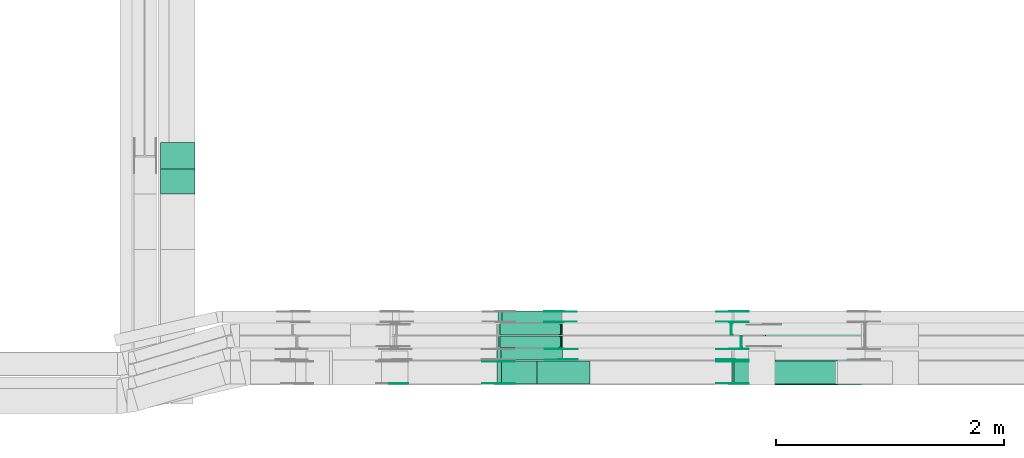
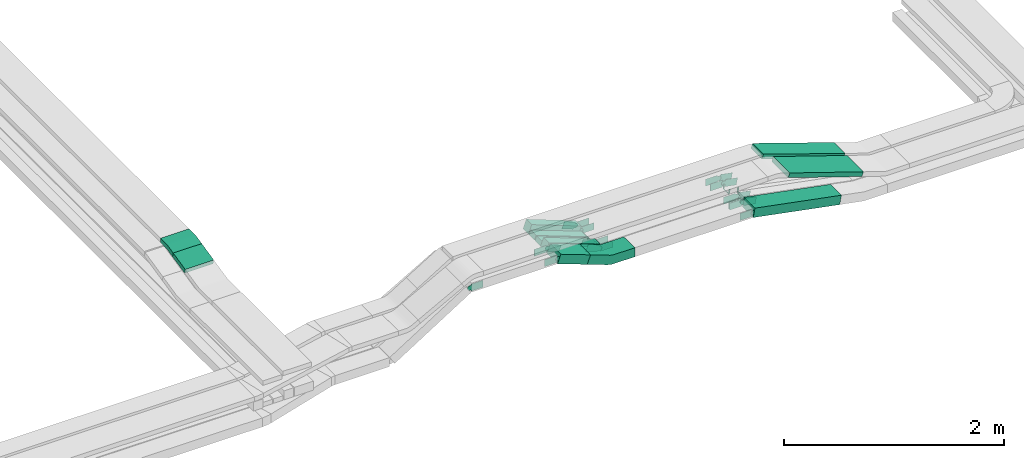
# One storey, part 24 of 28: 31 flow fittings, 9 flow segments.
"""IFC2X3 building model written with IfcOpenShell, lengths in millimetres."""

from ifc_helpers import new_model, entity, si_unit, converted_unit, derived_unit, direction, frame, frame_2d, origin, origin_2d_with_axis, place, context, subcontext, project, spatial, polyline, circle_curve, parameter, trimmed, segment, composite_curve, rectangle, outline, extrude, faceted_brep, source, transform, mapped, material, type_object, type_shapes, element, save


model = new_model("IFC2X3")

# Units and contexts
model_context = context("Model", 3, precision=0.01, world=origin(), true_north=direction((6.12303176911189e-17, 1.0)))
body_context = subcontext(model_context, "Body", "Model", "MODEL_VIEW")
ifc_project = project(units=[si_unit("LENGTHUNIT", "METRE", prefix="MILLI"), si_unit("AREAUNIT", "SQUARE_METRE"), si_unit("VOLUMEUNIT", "CUBIC_METRE"), converted_unit("PLANEANGLEUNIT", "DEGREE", entity("IfcRatioMeasure", 0.0174532925199433), si_unit("PLANEANGLEUNIT", "RADIAN"), dimensions=[0, 0, 0, 0, 0, 0, 0]), si_unit("MASSUNIT", "GRAM", prefix="KILO"), derived_unit("MASSDENSITYUNIT", [(si_unit("MASSUNIT", "GRAM", prefix="KILO"), 1), (si_unit("LENGTHUNIT", "METRE"), -3)]), derived_unit("MOMENTOFINERTIAUNIT", [(si_unit("LENGTHUNIT", "METRE"), 4)]), si_unit("TIMEUNIT", "SECOND"), si_unit("FREQUENCYUNIT", "HERTZ"), si_unit("THERMODYNAMICTEMPERATUREUNIT", "DEGREE_CELSIUS"), derived_unit("THERMALTRANSMITTANCEUNIT", [(si_unit("MASSUNIT", "GRAM", prefix="KILO"), 1), (si_unit("THERMODYNAMICTEMPERATUREUNIT", "KELVIN"), -1), (si_unit("TIMEUNIT", "SECOND"), -3)]), derived_unit("VOLUMETRICFLOWRATEUNIT", [(si_unit("LENGTHUNIT", "METRE"), 3), (si_unit("TIMEUNIT", "SECOND"), -1)]), derived_unit("MASSFLOWRATEUNIT", [(si_unit("MASSUNIT", "GRAM", prefix="KILO"), 1), (si_unit("TIMEUNIT", "SECOND"), -1)]), derived_unit("ROTATIONALFREQUENCYUNIT", [(si_unit("TIMEUNIT", "SECOND"), -1)]), si_unit("ELECTRICCURRENTUNIT", "AMPERE"), si_unit("ELECTRICVOLTAGEUNIT", "VOLT"), si_unit("POWERUNIT", "WATT"), si_unit("FORCEUNIT", "NEWTON", prefix="KILO"), si_unit("ILLUMINANCEUNIT", "LUX"), si_unit("LUMINOUSFLUXUNIT", "LUMEN"), si_unit("LUMINOUSINTENSITYUNIT", "CANDELA"), derived_unit("USERDEFINED", [(si_unit("MASSUNIT", "GRAM", prefix="KILO"), -1), (si_unit("LENGTHUNIT", "METRE"), -2), (si_unit("TIMEUNIT", "SECOND"), 3), (si_unit("LUMINOUSFLUXUNIT", "LUMEN"), 1)]), derived_unit("LINEARVELOCITYUNIT", [(si_unit("LENGTHUNIT", "METRE"), 1), (si_unit("TIMEUNIT", "SECOND"), -1)]), si_unit("PRESSUREUNIT", "PASCAL"), derived_unit("USERDEFINED", [(si_unit("LENGTHUNIT", "METRE"), -2), (si_unit("MASSUNIT", "GRAM", prefix="KILO"), 1), (si_unit("TIMEUNIT", "SECOND"), -2)]), derived_unit("LINEARFORCEUNIT", [(si_unit("MASSUNIT", "GRAM", prefix="KILO"), 1), (si_unit("LENGTHUNIT", "METRE"), 1), (si_unit("TIMEUNIT", "SECOND"), -2), (si_unit("LENGTHUNIT", "METRE"), -1)]), derived_unit("PLANARFORCEUNIT", [(si_unit("MASSUNIT", "GRAM", prefix="KILO"), 1), (si_unit("LENGTHUNIT", "METRE"), 1), (si_unit("TIMEUNIT", "SECOND"), -2), (si_unit("LENGTHUNIT", "METRE"), -2)])], contexts=[model_context])

# Site, building, storey
site_placement = place(None, origin())
site = spatial("IfcSite", under=ifc_project, at=site_placement, CompositionType="ELEMENT")
building_placement = place(site_placement, origin())
building = spatial("IfcBuilding", under=site, at=building_placement, CompositionType="ELEMENT")
storey_placement = place(building_placement, frame((0.0, 0.0, 15900.0)))
storey = spatial("IfcBuildingStorey", under=building, at=storey_placement, CompositionType="ELEMENT", Elevation=15900.0)

# Flow segments
cable_carrier_segment_type = type_object("IfcCableCarrierSegmentType", PredefinedType="CABLETRAYSEGMENT")
flow_segment_1_placement = place(storey_placement, frame((60480.82, 10142.24, 2935.93)))
element("IfcFlowSegment", 1, at=flow_segment_1_placement, inside=storey, type_object=cable_carrier_segment_type, context=body_context, shape_type="SweptSolid", body=[
    extrude(rectangle(XDim=49.999999999999, YDim=224.379471632193, at=frame_2d((0.0, 0.0), x_axis=(0.0, 1.0))), frame((0.0, 114.94, 49.17), z_axis=(1.0, 0.0, 0.0), x_axis=(0.0, 0.975283876332618, 0.220955562422907)), (0.0, 0.0, 1.0), 300.000000000001),
])
flow_segment_2_placement = place(storey_placement, frame((63434.61, 8474.97, 2908.57)))
element("IfcFlowSegment", 2, at=flow_segment_2_placement, inside=storey, type_object=cable_carrier_segment_type, context=body_context, shape_type="SweptSolid", body=[
    extrude(rectangle(XDim=100.000000000008, YDim=200.0, at=origin_2d_with_axis()), frame((17.45, 100.0, 163.12), z_axis=(0.93710827946644, 0.0, -0.349038783741073), x_axis=(0.349038783741073, 0.0, 0.93710827946644)), (0.0, 0.0, 1.0), 333.090848665879),
])
flow_segment_3_placement = place(storey_placement, frame((63431.17, 8684.97, 2825.3)))
element("IfcFlowSegment", 3, at=flow_segment_3_placement, inside=storey, type_object=cable_carrier_segment_type, context=body_context, shape_type="SweptSolid", body=[
    extrude(rectangle(XDim=99.9999999999998, YDim=99.9999999999989, at=origin_2d_with_axis()), frame((17.36, 50.0, 246.43), z_axis=(0.937801944103858, 0.0, -0.347170726927005), x_axis=(0.347170726927005, 0.0, 0.937801944103858)), (0.0, 0.0, 1.0), 574.76976896054),
])
flow_segment_4_placement = place(storey_placement, frame((63439.05, 8794.97, 2823.23)))
element("IfcFlowSegment", 4, at=flow_segment_4_placement, inside=storey, type_object=cable_carrier_segment_type, context=body_context, shape_type="SweptSolid", body=[
    extrude(rectangle(XDim=49.9999999999989, YDim=99.9999999999989, at=origin_2d_with_axis()), frame((8.75, 50.0, 224.05), z_axis=(0.936732432746274, 0.0, -0.350046210436919), x_axis=(0.350046210436919, 0.0, 0.936732432746274)), (0.0, 0.0, 1.0), 573.147793888569),
])
flow_segment_5_placement = place(storey_placement, frame((63439.91, 8904.97, 2823.24)))
element("IfcFlowSegment", 5, at=flow_segment_5_placement, inside=storey, type_object=cable_carrier_segment_type, context=body_context, shape_type="SweptSolid", body=[
    extrude(rectangle(XDim=50.0000000000006, YDim=100.000000000001, at=origin_2d_with_axis()), frame((8.76, 50.0, 224.03), z_axis=(0.936565915076029, 0.0, -0.350491493074798), x_axis=(0.350491493074798, 0.0, 0.936565915076029)), (0.0, 0.0, 1.0), 572.372127334818),
])
flow_segment_6_placement = place(storey_placement, frame((63439.46, 9014.97, 2825.64)))
element("IfcFlowSegment", 6, at=flow_segment_6_placement, inside=storey, type_object=cable_carrier_segment_type, context=body_context, shape_type="SweptSolid", body=[
    extrude(rectangle(XDim=99.9999999999993, YDim=100.000000000001, at=origin_2d_with_axis()), frame((17.79, 50.0, 245.91), z_axis=(0.934589453965198, 0.0, -0.355728200367967), x_axis=(0.355728200367967, 0.0, 0.934589453965198)), (0.0, 0.0, 1.0), 559.919552112584),
])
flow_segment_7_placement = place(storey_placement, frame((65492.26, 8474.97, 2643.47)))
element("IfcFlowSegment", 7, at=flow_segment_7_placement, inside=storey, type_object=cable_carrier_segment_type, context=body_context, shape_type="SweptSolid", body=[
    extrude(rectangle(XDim=100.000000000002, YDim=200.0, at=origin_2d_with_axis()), frame((9.43, 100.0, 223.85), z_axis=(0.982035536310349, 0.0, -0.188696066264366), x_axis=(0.188696066264366, 0.0, 0.982035536310349)), (0.0, 0.0, 1.0), 926.06458101267),
])
flow_segment_8_placement = place(storey_placement, frame((65854.05, 8465.15, 2881.95)))
element("IfcFlowSegment", 8, at=flow_segment_8_placement, inside=storey, type_object=cable_carrier_segment_type, context=body_context, shape_type="SweptSolid", body=[
    extrude(rectangle(XDim=50.0000000000008, YDim=300.000000000001, at=origin_2d_with_axis()), frame((7.9, 150.0, 282.03), z_axis=(0.948754815223127, 0.0, -0.316013133573479), x_axis=(0.316013133573479, 0.0, 0.948754815223127)), (0.0, 0.0, 1.0), 817.406380375089),
])
flow_segment_9_placement = place(storey_placement, frame((65771.27, 8800.15, 2883.35)))
element("IfcFlowSegment", 9, at=flow_segment_9_placement, inside=storey, type_object=cable_carrier_segment_type, context=body_context, shape_type="SweptSolid", body=[
    extrude(rectangle(XDim=50.000000000002, YDim=200.0, at=origin_2d_with_axis()), frame((8.03, 100.0, 314.8), z_axis=(0.947026352753396, 0.0, -0.321155861211656), x_axis=(0.321155861211656, 0.0, 0.947026352753396)), (0.0, 0.0, 1.0), 906.476874126866),
])

# Flow fittings
ifc_material_1 = material()
cable_carrier_fitting_type_1 = type_object("IfcCableCarrierFittingType", PredefinedType="NOTDEFINED", material=ifc_material_1)
shared_shape_1 = source(origin(), body_context, "Body", "Brep", [
    faceted_brep([(-9.04, 25.0, 50.0), (-9.04, 25.0, -50.0), (-9.04, -25.0, -50.0), (-9.04, -25.0, -47.46), (-9.04, 22.46, -47.46), (-9.04, 22.46, 47.46), (-9.04, -25.0, 47.46), (-9.04, -25.0, 50.0), (-0.29, 26.58, 50.0), (17.22, -20.25, 50.0), (17.22, -20.25, 47.46), (0.6, 24.2, 47.46), (0.6, 24.2, -47.46), (17.22, -20.25, -47.46), (17.22, -20.25, -50.0), (-0.29, 26.58, -50.0), (-4.52, 25.0, 50.0), (-4.52, 25.0, -50.0), (4.52, -25.0, -50.0), (4.52, -25.0, -47.46), (-4.06, 22.46, -47.46), (-4.06, 22.46, 47.46), (4.52, -25.0, 47.46), (4.52, -25.0, 50.0)], [[[0, 1, 2, 3, 4, 5, 6, 7]], [[8, 9, 10, 11, 12, 13, 14, 15]], [[1, 0, 16, 17]], [[2, 1, 17, 15, 14, 18]], [[3, 2, 18, 19]], [[4, 3, 19, 13, 12, 20]], [[5, 4, 20, 21]], [[6, 5, 21, 11, 10, 22]], [[7, 6, 22, 23]], [[0, 7, 23, 9, 8, 16]], [[17, 16, 8, 15]], [[19, 18, 14, 13]], [[21, 20, 12, 11]], [[23, 22, 10, 9]]]),
])
type_shapes(cable_carrier_fitting_type_1, [shared_shape_1])
flow_fitting_1_placement = place(storey_placement, frame((63993.15, 8844.97, 2843.48), z_axis=(0.0, -1.0, 0.0), x_axis=(0.936732432746256, 0.0, -0.350046210436966)))
element("IfcFlowFitting", 10, at=flow_fitting_1_placement, inside=storey, type_object=cable_carrier_fitting_type_1, material=ifc_material_1, context=body_context, shape_type="MappedRepresentation", body=[
    mapped(shared_shape_1, transform((0.0, 0.0, 0.0), scale=1.0)),
])
cable_carrier_fitting_type_2 = type_object("IfcCableCarrierFittingType", PredefinedType="NOTDEFINED", material=ifc_material_1)
shared_shape_2 = source(origin(), body_context, "Body", "Brep", [
    faceted_brep([(-9.05, 25.0, 50.0), (-9.05, 25.0, -50.0), (-9.05, -25.0, -50.0), (-9.05, -25.0, -47.46), (-9.05, 22.46, -47.46), (-9.05, 22.46, 47.46), (-9.05, -25.0, 47.46), (-9.05, -25.0, 50.0), (-0.29, 26.59, 50.0), (17.24, -20.24, 50.0), (17.24, -20.24, 47.46), (0.6, 24.21, 47.46), (0.6, 24.21, -47.46), (17.24, -20.24, -47.46), (17.24, -20.24, -50.0), (-0.29, 26.59, -50.0), (-4.52, 25.0, 50.0), (-4.52, 25.0, -50.0), (4.52, -25.0, -50.0), (4.52, -25.0, -47.46), (-4.06, 22.46, -47.46), (-4.06, 22.46, 47.46), (4.52, -25.0, 47.46), (4.52, -25.0, 50.0)], [[[0, 1, 2, 3, 4, 5, 6, 7]], [[8, 9, 10, 11, 12, 13, 14, 15]], [[1, 0, 16, 17]], [[2, 1, 17, 15, 14, 18]], [[3, 2, 18, 19]], [[4, 3, 19, 13, 12, 20]], [[5, 4, 20, 21]], [[6, 5, 21, 11, 10, 22]], [[7, 6, 22, 23]], [[0, 7, 23, 9, 8, 16]], [[17, 16, 8, 15]], [[19, 18, 14, 13]], [[21, 20, 12, 11]], [[23, 22, 10, 9]]]),
])
type_shapes(cable_carrier_fitting_type_2, [shared_shape_2])
flow_fitting_2_placement = place(storey_placement, frame((63993.21, 8954.97, 2843.48), z_axis=(0.0, 1.0, 0.0), x_axis=(-1.0, 0.0, 0.0)))
element("IfcFlowFitting", 11, at=flow_fitting_2_placement, inside=storey, type_object=cable_carrier_fitting_type_2, material=ifc_material_1, context=body_context, shape_type="MappedRepresentation", body=[
    mapped(shared_shape_2, transform((0.0, 0.0, 0.0), scale=1.0)),
])
cable_carrier_fitting_type_3 = type_object("IfcCableCarrierFittingType", PredefinedType="NOTDEFINED", material=ifc_material_1)
shared_shape_3 = source(origin(), body_context, "Body", "Brep", [
    faceted_brep([(-5.06, 25.0, 50.0), (-5.06, 25.0, -50.0), (-5.06, -25.0, -50.0), (-5.06, -25.0, -47.46), (-5.06, 22.46, -47.46), (-5.06, 22.46, 47.46), (-5.06, -25.0, 47.46), (-5.06, -25.0, 50.0), (-0.05, 25.51, 50.0), (9.97, -23.48, 50.0), (9.97, -23.48, 47.46), (0.46, 23.02, 47.46), (0.46, 23.02, -47.46), (9.97, -23.48, -47.46), (9.97, -23.48, -50.0), (-0.05, 25.51, -50.0), (-2.53, 25.0, 50.0), (-2.53, 25.0, -50.0), (2.53, -25.0, -50.0), (2.53, -25.0, -47.46), (-2.27, 22.46, -47.46), (-2.27, 22.46, 47.46), (2.53, -25.0, 47.46), (2.53, -25.0, 50.0)], [[[0, 1, 2, 3, 4, 5, 6, 7]], [[8, 9, 10, 11, 12, 13, 14, 15]], [[1, 0, 16, 17]], [[2, 1, 17, 15, 14, 18]], [[3, 2, 18, 19]], [[4, 3, 19, 13, 12, 20]], [[5, 4, 20, 21]], [[6, 5, 21, 11, 10, 22]], [[7, 6, 22, 23]], [[0, 7, 23, 9, 8, 16]], [[17, 16, 8, 15]], [[19, 18, 14, 13]], [[21, 20, 12, 11]], [[23, 22, 10, 9]]]),
])
type_shapes(cable_carrier_fitting_type_3, [shared_shape_3])
flow_fitting_3_placement = place(storey_placement, frame((65573.15, 8844.97, 2843.48), z_axis=(0.0, 1.0, 0.0), x_axis=(1.0, 0.0, 0.0)))
element("IfcFlowFitting", 12, at=flow_fitting_3_placement, inside=storey, type_object=cable_carrier_fitting_type_3, material=ifc_material_1, context=body_context, shape_type="MappedRepresentation", body=[
    mapped(shared_shape_3, transform((0.0, 0.0, 0.0), scale=1.0)),
])
cable_carrier_fitting_type_4 = type_object("IfcCableCarrierFittingType", PredefinedType="NOTDEFINED", material=ifc_material_1)
shared_shape_4 = source(origin(), body_context, "Body", "Brep", [
    faceted_brep([(-4.7, 25.0, 50.0), (-4.7, 25.0, -50.0), (-4.7, -25.0, -50.0), (-4.7, -25.0, -47.46), (-4.7, 22.46, -47.46), (-4.7, 22.46, 47.46), (-4.7, -25.0, 47.46), (-4.7, -25.0, 50.0), (-0.04, 25.44, 50.0), (9.28, -23.69, 50.0), (9.28, -23.69, 47.46), (0.43, 22.94, 47.46), (0.43, 22.94, -47.46), (9.28, -23.69, -47.46), (9.28, -23.69, -50.0), (-0.04, 25.44, -50.0), (-2.35, 25.0, 50.0), (-2.35, 25.0, -50.0), (2.35, -25.0, -50.0), (2.35, -25.0, -47.46), (-2.11, 22.46, -47.46), (-2.11, 22.46, 47.46), (2.35, -25.0, 47.46), (2.35, -25.0, 50.0)], [[[0, 1, 2, 3, 4, 5, 6, 7]], [[8, 9, 10, 11, 12, 13, 14, 15]], [[1, 0, 16, 17]], [[2, 1, 17, 15, 14, 18]], [[3, 2, 18, 19]], [[4, 3, 19, 13, 12, 20]], [[5, 4, 20, 21]], [[6, 5, 21, 11, 10, 22]], [[7, 6, 22, 23]], [[0, 7, 23, 9, 8, 16]], [[17, 16, 8, 15]], [[19, 18, 14, 13]], [[21, 20, 12, 11]], [[23, 22, 10, 9]]]),
])
type_shapes(cable_carrier_fitting_type_4, [shared_shape_4])
flow_fitting_4_placement = place(storey_placement, frame((65488.23, 8954.97, 2843.48), z_axis=(0.0, 1.0, 0.0), x_axis=(1.0, 0.0, 0.0)))
element("IfcFlowFitting", 13, at=flow_fitting_4_placement, inside=storey, type_object=cable_carrier_fitting_type_4, material=ifc_material_1, context=body_context, shape_type="MappedRepresentation", body=[
    mapped(shared_shape_4, transform((0.0, 0.0, 0.0), scale=1.0)),
])
ifc_material_2 = material(Name="G")
cable_carrier_fitting_type_5 = type_object("IfcCableCarrierFittingType", PredefinedType="NOTDEFINED", material=ifc_material_2)
shared_shape_5 = source(origin(), body_context, "Body", "SweptSolid", [
    extrude(outline(composite_curve([segment(trimmed(circle_curve(frame_2d((-41.47, 0.0), x_axis=(1.0, 0.0)), 25.0), [parameter(90.0000000000007)], [parameter(270.0)], True, "PARAMETER"), True, "CONTINUOUS"), segment(polyline([(-41.47, -25.0), (-29.97, -25.0)]), True, "CONTINUOUS"), segment(polyline([(-29.97, -25.0), (-28.1, -38.5)]), True, "CONTINUOUS"), segment(polyline([(-28.1, -38.5), (99.53, -38.5)]), True, "CONTINUOUS"), segment(polyline([(99.53, -38.5), (99.53, 38.5)]), True, "CONTINUOUS"), segment(polyline([(99.53, 38.5), (-28.1, 38.5)]), True, "CONTINUOUS"), segment(polyline([(-28.1, 38.5), (-29.97, 25.0)]), True, "CONTINUOUS"), segment(polyline([(-29.97, 25.0), (-41.47, 25.0)]), True, "CONTINUOUS")], self_intersect=False)), frame((41.47, 0.0, 0.0), z_axis=(0.0, 0.0, -1.0), x_axis=(1.0, 0.0, 0.0)), (0.0, 0.0, -1.0), 2.0),
])
type_shapes(cable_carrier_fitting_type_5, [shared_shape_5])
flow_fitting_5_placement = place(storey_placement, frame((65495.66, 8780.43, 2868.48), z_axis=(0.0, 1.0, 0.0), x_axis=(0.982035536310358, 0.0, -0.188696066264316)))
element("IfcFlowFitting", 14, at=flow_fitting_5_placement, inside=storey, type_object=cable_carrier_fitting_type_5, material=ifc_material_2, context=body_context, shape_type="MappedRepresentation", body=[
    mapped(shared_shape_5, transform((0.0, 0.0, 0.0), scale=1.0)),
])
cable_carrier_fitting_type_6 = type_object("IfcCableCarrierFittingType", PredefinedType="NOTDEFINED", material=ifc_material_2)
type_shapes(cable_carrier_fitting_type_6, [shared_shape_5])
flow_fitting_6_placement = place(storey_placement, frame((65495.66, 8691.51, 2868.48), z_axis=(0.0, -1.0, 0.0), x_axis=(-1.0, 0.0, 0.0)))
element("IfcFlowFitting", 15, at=flow_fitting_6_placement, inside=storey, type_object=cable_carrier_fitting_type_6, material=ifc_material_2, context=body_context, shape_type="MappedRepresentation", body=[
    mapped(shared_shape_5, transform((0.0, 0.0, 0.0), scale=1.0)),
])
flow_fitting_7_placement = place(storey_placement, frame((65495.66, 9110.43, 2868.48), z_axis=(0.0, 1.0, 0.0), x_axis=(0.982035536310358, 0.0, -0.188696066264316)))
element("IfcFlowFitting", 16, at=flow_fitting_7_placement, inside=storey, type_object=cable_carrier_fitting_type_5, material=ifc_material_2, context=body_context, shape_type="MappedRepresentation", body=[
    mapped(shared_shape_5, transform((0.0, 0.0, 0.0), scale=1.0)),
])
flow_fitting_8_placement = place(storey_placement, frame((65495.66, 9021.51, 2868.48), z_axis=(0.0, -1.0, 0.0), x_axis=(-1.0, 0.0, 0.0)))
element("IfcFlowFitting", 17, at=flow_fitting_8_placement, inside=storey, type_object=cable_carrier_fitting_type_6, material=ifc_material_2, context=body_context, shape_type="MappedRepresentation", body=[
    mapped(shared_shape_5, transform((0.0, 0.0, 0.0), scale=1.0)),
])
flow_fitting_9_placement = place(storey_placement, frame((63997.56, 8780.43, 2868.48), z_axis=(0.0, 1.0, 0.0), x_axis=(-0.937801944103825, 0.0, 0.347170726927093)))
element("IfcFlowFitting", 18, at=flow_fitting_9_placement, inside=storey, type_object=cable_carrier_fitting_type_5, material=ifc_material_2, context=body_context, shape_type="MappedRepresentation", body=[
    mapped(shared_shape_5, transform((0.0, 0.0, 0.0), scale=1.0)),
])
flow_fitting_10_placement = place(storey_placement, frame((63997.56, 8691.51, 2868.48), z_axis=(0.0, -1.0, 0.0), x_axis=(1.0, 0.0, 0.0)))
element("IfcFlowFitting", 19, at=flow_fitting_10_placement, inside=storey, type_object=cable_carrier_fitting_type_6, material=ifc_material_2, context=body_context, shape_type="MappedRepresentation", body=[
    mapped(shared_shape_5, transform((0.0, 0.0, 0.0), scale=1.0)),
])
flow_fitting_11_placement = place(storey_placement, frame((63990.75, 9110.43, 2868.48), z_axis=(0.0, 1.0, 0.0), x_axis=(-0.934589453965168, 0.0, 0.355728200368047)))
element("IfcFlowFitting", 20, at=flow_fitting_11_placement, inside=storey, type_object=cable_carrier_fitting_type_5, material=ifc_material_2, context=body_context, shape_type="MappedRepresentation", body=[
    mapped(shared_shape_5, transform((0.0, 0.0, 0.0), scale=1.0)),
])
flow_fitting_12_placement = place(storey_placement, frame((63990.75, 9021.51, 2868.48), z_axis=(0.0, -1.0, 0.0), x_axis=(1.0, 0.0, 0.0)))
element("IfcFlowFitting", 21, at=flow_fitting_12_placement, inside=storey, type_object=cable_carrier_fitting_type_6, material=ifc_material_2, context=body_context, shape_type="MappedRepresentation", body=[
    mapped(shared_shape_5, transform((0.0, 0.0, 0.0), scale=1.0)),
])
flow_fitting_13_placement = place(storey_placement, frame((63442.0, 8670.43, 3075.44), z_axis=(0.0, 1.0, 0.0), x_axis=(0.937108279466473, 0.0, -0.349038783740986)))
element("IfcFlowFitting", 22, at=flow_fitting_13_placement, inside=storey, type_object=cable_carrier_fitting_type_5, material=ifc_material_2, context=body_context, shape_type="MappedRepresentation", body=[
    mapped(shared_shape_5, transform((0.0, 0.0, 0.0), scale=1.0)),
])
flow_fitting_14_placement = place(storey_placement, frame((63442.0, 8481.51, 3075.44), z_axis=(0.0, -1.0, 0.0), x_axis=(-1.0, 0.0, 0.0)))
element("IfcFlowFitting", 23, at=flow_fitting_14_placement, inside=storey, type_object=cable_carrier_fitting_type_6, material=ifc_material_2, context=body_context, shape_type="MappedRepresentation", body=[
    mapped(shared_shape_5, transform((0.0, 0.0, 0.0), scale=1.0)),
])
flow_fitting_15_placement = place(storey_placement, frame((65495.66, 8670.43, 2868.48), z_axis=(0.0, 1.0, 0.0), x_axis=(0.982035536310354, 0.0, -0.18869606626434)))
element("IfcFlowFitting", 24, at=flow_fitting_15_placement, inside=storey, type_object=cable_carrier_fitting_type_5, material=ifc_material_2, context=body_context, shape_type="MappedRepresentation", body=[
    mapped(shared_shape_5, transform((0.0, 0.0, 0.0), scale=1.0)),
])
flow_fitting_16_placement = place(storey_placement, frame((65495.66, 8481.51, 2868.48), z_axis=(0.0, -1.0, 0.0), x_axis=(-1.0, 0.0, 0.0)))
element("IfcFlowFitting", 25, at=flow_fitting_16_placement, inside=storey, type_object=cable_carrier_fitting_type_6, material=ifc_material_2, context=body_context, shape_type="MappedRepresentation", body=[
    mapped(shared_shape_5, transform((0.0, 0.0, 0.0), scale=1.0)),
])
cable_carrier_fitting_type_7 = type_object("IfcCableCarrierFittingType", PredefinedType="NOTDEFINED", material=ifc_material_2)
shared_shape_6 = source(origin(), body_context, "Body", "SweptSolid", [
    extrude(outline(composite_curve([segment(trimmed(circle_curve(frame_2d((-41.47, 0.0), x_axis=(1.0, 0.0)), 25.0), [parameter(90.0000000000007)], [parameter(270.0)], True, "PARAMETER"), True, "CONTINUOUS"), segment(polyline([(-41.47, -25.0), (-29.97, -25.0)]), True, "CONTINUOUS"), segment(polyline([(-29.97, -25.0), (-28.1, -38.5)]), True, "CONTINUOUS"), segment(polyline([(-28.1, -38.5), (99.53, -38.5)]), True, "CONTINUOUS"), segment(polyline([(99.53, -38.5), (99.53, 38.5)]), True, "CONTINUOUS"), segment(polyline([(99.53, 38.5), (-28.1, 38.5)]), True, "CONTINUOUS"), segment(polyline([(-28.1, 38.5), (-29.97, 25.0)]), True, "CONTINUOUS"), segment(polyline([(-29.97, 25.0), (-41.47, 25.0)]), True, "CONTINUOUS")], self_intersect=False)), frame((41.47, 0.0, 0.0)), (0.0, 0.0, 1.0), 2.0),
])
type_shapes(cable_carrier_fitting_type_7, [shared_shape_6])
flow_fitting_17_placement = place(storey_placement, frame((65495.66, 8689.51, 2868.48), z_axis=(0.0, -1.0, 0.0), x_axis=(0.982035536310358, 0.0, -0.188696066264316)))
element("IfcFlowFitting", 26, at=flow_fitting_17_placement, inside=storey, type_object=cable_carrier_fitting_type_7, material=ifc_material_2, context=body_context, shape_type="MappedRepresentation", body=[
    mapped(shared_shape_6, transform((0.0, 0.0, 0.0), scale=1.0)),
])
cable_carrier_fitting_type_8 = type_object("IfcCableCarrierFittingType", PredefinedType="NOTDEFINED", material=ifc_material_2)
type_shapes(cable_carrier_fitting_type_8, [shared_shape_6])
flow_fitting_18_placement = place(storey_placement, frame((65495.66, 8778.43, 2868.48), z_axis=(0.0, 1.0, 0.0), x_axis=(-1.0, 0.0, 0.0)))
element("IfcFlowFitting", 27, at=flow_fitting_18_placement, inside=storey, type_object=cable_carrier_fitting_type_8, material=ifc_material_2, context=body_context, shape_type="MappedRepresentation", body=[
    mapped(shared_shape_6, transform((0.0, 0.0, 0.0), scale=1.0)),
])
flow_fitting_19_placement = place(storey_placement, frame((65495.66, 9019.51, 2868.48), z_axis=(0.0, -1.0, 0.0), x_axis=(0.982035536310358, 0.0, -0.188696066264316)))
element("IfcFlowFitting", 28, at=flow_fitting_19_placement, inside=storey, type_object=cable_carrier_fitting_type_7, material=ifc_material_2, context=body_context, shape_type="MappedRepresentation", body=[
    mapped(shared_shape_6, transform((0.0, 0.0, 0.0), scale=1.0)),
])
flow_fitting_20_placement = place(storey_placement, frame((65495.66, 9108.43, 2868.48), z_axis=(0.0, 1.0, 0.0), x_axis=(-1.0, 0.0, 0.0)))
element("IfcFlowFitting", 29, at=flow_fitting_20_placement, inside=storey, type_object=cable_carrier_fitting_type_8, material=ifc_material_2, context=body_context, shape_type="MappedRepresentation", body=[
    mapped(shared_shape_6, transform((0.0, 0.0, 0.0), scale=1.0)),
])
flow_fitting_21_placement = place(storey_placement, frame((63997.56, 8689.51, 2868.48), z_axis=(0.0, -1.0, 0.0), x_axis=(-0.937801944103825, 0.0, 0.347170726927093)))
element("IfcFlowFitting", 30, at=flow_fitting_21_placement, inside=storey, type_object=cable_carrier_fitting_type_7, material=ifc_material_2, context=body_context, shape_type="MappedRepresentation", body=[
    mapped(shared_shape_6, transform((0.0, 0.0, 0.0), scale=1.0)),
])
flow_fitting_22_placement = place(storey_placement, frame((63997.56, 8778.43, 2868.48), z_axis=(0.0, 1.0, 0.0), x_axis=(1.0, 0.0, 0.0)))
element("IfcFlowFitting", 31, at=flow_fitting_22_placement, inside=storey, type_object=cable_carrier_fitting_type_8, material=ifc_material_2, context=body_context, shape_type="MappedRepresentation", body=[
    mapped(shared_shape_6, transform((0.0, 0.0, 0.0), scale=1.0)),
])
flow_fitting_23_placement = place(storey_placement, frame((63990.75, 9019.51, 2868.48), z_axis=(0.0, -1.0, 0.0), x_axis=(-0.934589453965168, 0.0, 0.355728200368047)))
element("IfcFlowFitting", 32, at=flow_fitting_23_placement, inside=storey, type_object=cable_carrier_fitting_type_7, material=ifc_material_2, context=body_context, shape_type="MappedRepresentation", body=[
    mapped(shared_shape_6, transform((0.0, 0.0, 0.0), scale=1.0)),
])
flow_fitting_24_placement = place(storey_placement, frame((63990.75, 9108.43, 2868.48), z_axis=(0.0, 1.0, 0.0), x_axis=(1.0, 0.0, 0.0)))
element("IfcFlowFitting", 33, at=flow_fitting_24_placement, inside=storey, type_object=cable_carrier_fitting_type_8, material=ifc_material_2, context=body_context, shape_type="MappedRepresentation", body=[
    mapped(shared_shape_6, transform((0.0, 0.0, 0.0), scale=1.0)),
])
for number, where, z_axis, x_axis in (
    (34, (62513.11, 8479.51, 3075.44), (0.0, -1.0, 0.0), (1.0, 0.0, 0.0)),
    (35, (63442.0, 8479.51, 3075.44), (0.0, -1.0, 0.0), (0.937108279466473, 0.0, -0.349038783740986)),
):
    element("IfcFlowFitting", number, at=place(storey_placement, frame(where, z_axis=z_axis, x_axis=x_axis)), inside=storey, type_object=cable_carrier_fitting_type_7, material=ifc_material_2, context=body_context, shape_type="MappedRepresentation", body=[
        mapped(shared_shape_6, transform((0.0, 0.0, 0.0), scale=1.0)),
    ])
flow_fitting_25_placement = place(storey_placement, frame((63442.0, 8668.43, 3075.44), z_axis=(0.0, 1.0, 0.0), x_axis=(-1.0, 0.0, 0.0)))
element("IfcFlowFitting", 36, at=flow_fitting_25_placement, inside=storey, type_object=cable_carrier_fitting_type_8, material=ifc_material_2, context=body_context, shape_type="MappedRepresentation", body=[
    mapped(shared_shape_6, transform((0.0, 0.0, 0.0), scale=1.0)),
])
flow_fitting_26_placement = place(storey_placement, frame((65495.66, 8479.51, 2868.48), z_axis=(0.0, -1.0, 0.0), x_axis=(0.982035536310354, 0.0, -0.18869606626434)))
element("IfcFlowFitting", 37, at=flow_fitting_26_placement, inside=storey, type_object=cable_carrier_fitting_type_7, material=ifc_material_2, context=body_context, shape_type="MappedRepresentation", body=[
    mapped(shared_shape_6, transform((0.0, 0.0, 0.0), scale=1.0)),
])
flow_fitting_27_placement = place(storey_placement, frame((65495.66, 8668.43, 2868.48), z_axis=(0.0, 1.0, 0.0), x_axis=(-1.0, 0.0, 0.0)))
element("IfcFlowFitting", 38, at=flow_fitting_27_placement, inside=storey, type_object=cable_carrier_fitting_type_8, material=ifc_material_2, context=body_context, shape_type="MappedRepresentation", body=[
    mapped(shared_shape_6, transform((0.0, 0.0, 0.0), scale=1.0)),
])
cable_carrier_fitting_type_9 = type_object("IfcCableCarrierFittingType", Name="470_DKC_S5_CD 90 external vertical angle:-", PredefinedType="NOTDEFINED", material=ifc_material_1)
shared_shape_7 = source(origin(), body_context, "Body", "SweptSolid", [
    extrude(outline(composite_curve([segment(polyline([(-112.83, -32.3), (-17.64, -32.3)]), True, "CONTINUOUS"), segment(trimmed(circle_curve(frame_2d((-17.64, 157.7), x_axis=(0.0, -1.0)), 189.999999999999), [parameter(0.0)], [parameter(12.7651639618241)], True, "PARAMETER"), True, "CONTINUOUS"), segment(polyline([(24.34, -27.6), (117.17, -6.57)]), True, "CONTINUOUS"), segment(polyline([(117.17, -6.57), (106.13, 42.2)]), True, "CONTINUOUS"), segment(polyline([(106.13, 42.2), (13.29, 21.16)]), True, "CONTINUOUS"), segment(trimmed(circle_curve(frame_2d((-17.64, 157.7), x_axis=(0.0, -1.0)), 139.999999999999), [parameter(0.0)], [parameter(12.7651639618241)], True, "PARAMETER"), False, "CONTINUOUS"), segment(polyline([(-17.64, 17.7), (-112.83, 17.7)]), True, "CONTINUOUS"), segment(polyline([(-112.83, 17.7), (-112.83, -32.3)]), True, "CONTINUOUS")], self_intersect=False)), frame((-0.82, 7.3, -150.0)), (0.0, 0.0, 1.0), 300.0),
])
type_shapes(cable_carrier_fitting_type_9, [shared_shape_7])
flow_fitting_28_placement = place(storey_placement, frame((60630.82, 10477.43, 3035.0), z_axis=(1.0, 0.0, 0.0), x_axis=(0.0, -1.0, 0.0)))
element("IfcFlowFitting", 39, at=flow_fitting_28_placement, inside=storey, type_object=cable_carrier_fitting_type_9, material=ifc_material_1, Name="470_DKC_S5_CD 90 external vertical angle:-", ObjectType="470_DKC_S5_CD 90 external vertical angle:-", context=body_context, shape_type="MappedRepresentation", body=[
    mapped(shared_shape_7, transform((0.0, 0.0, 0.0), scale=1.0)),
])
cable_carrier_fitting_type_10 = type_object("IfcCableCarrierFittingType", Name="470_DKC_S5_CS 90 internal vertical angle:-", PredefinedType="NOTDEFINED", material=ifc_material_1)
shared_shape_8 = source(origin(), body_context, "Body", "SweptSolid", [
    extrude(outline(composite_curve([segment(polyline([(-244.72, -74.33), (-25.35, -74.33)]), True, "CONTINUOUS"), segment(trimmed(circle_curve(frame_2d((-25.35, 140.67), x_axis=(0.0, -1.0)), 214.999999999999), [parameter(0.0)], [parameter(20.4285341071695)], True, "PARAMETER"), True, "CONTINUOUS"), segment(polyline([(49.7, -60.81), (255.28, 15.76)]), True, "CONTINUOUS"), segment(polyline([(255.28, 15.76), (220.37, 109.47)]), True, "CONTINUOUS"), segment(polyline([(220.37, 109.47), (14.79, 32.9)]), True, "CONTINUOUS"), segment(trimmed(circle_curve(frame_2d((-25.35, 140.67), x_axis=(0.0, -1.0)), 114.999999999999), [parameter(0.0)], [parameter(20.4285341071695)], True, "PARAMETER"), False, "CONTINUOUS"), segment(polyline([(-25.35, 25.67), (-244.72, 25.67)]), True, "CONTINUOUS"), segment(polyline([(-244.72, 25.67), (-244.72, -74.33)]), True, "CONTINUOUS")], self_intersect=False)), frame((-4.38, 24.33, -100.0)), (0.0, 0.0, 1.0), 200.0),
])
type_shapes(cable_carrier_fitting_type_10, [shared_shape_8])
flow_fitting_29_placement = place(storey_placement, frame((63997.64, 8574.97, 2868.48), z_axis=(0.0, 1.0, 0.0), x_axis=(-1.0, 0.0, 0.0)))
element("IfcFlowFitting", 40, at=flow_fitting_29_placement, inside=storey, type_object=cable_carrier_fitting_type_10, material=ifc_material_1, Name="470_DKC_S5_CS 90 internal vertical angle:-", ObjectType="470_DKC_S5_CS 90 internal vertical angle:-", context=body_context, shape_type="MappedRepresentation", body=[
    mapped(shared_shape_8, transform((0.0, 0.0, 0.0), scale=1.0)),
])

save(model, "model.ifc")
